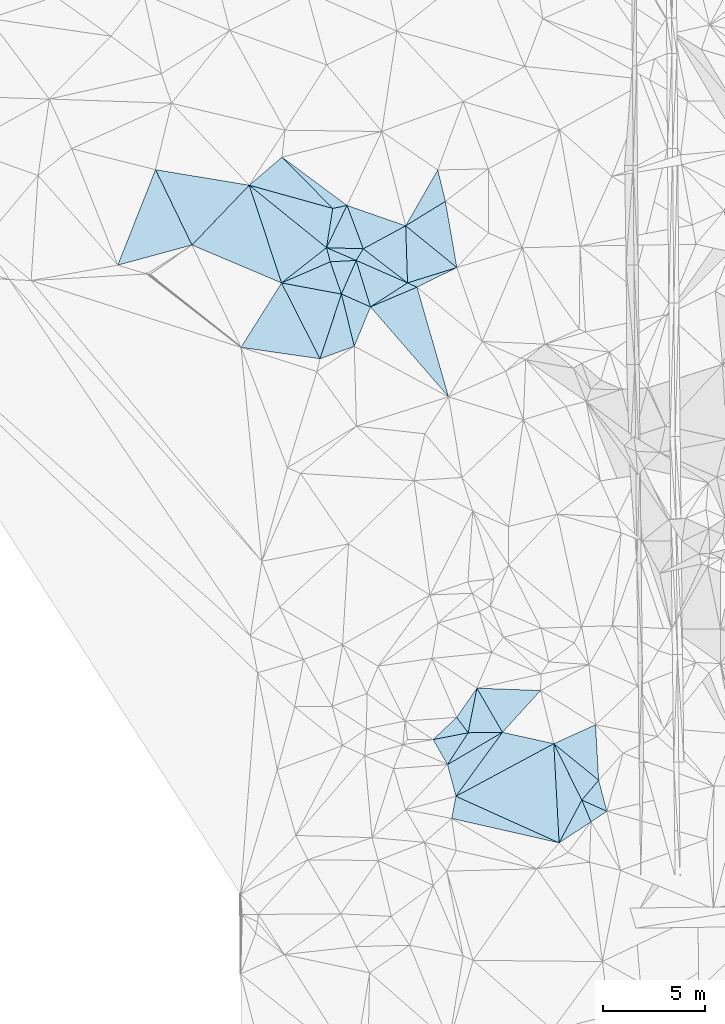
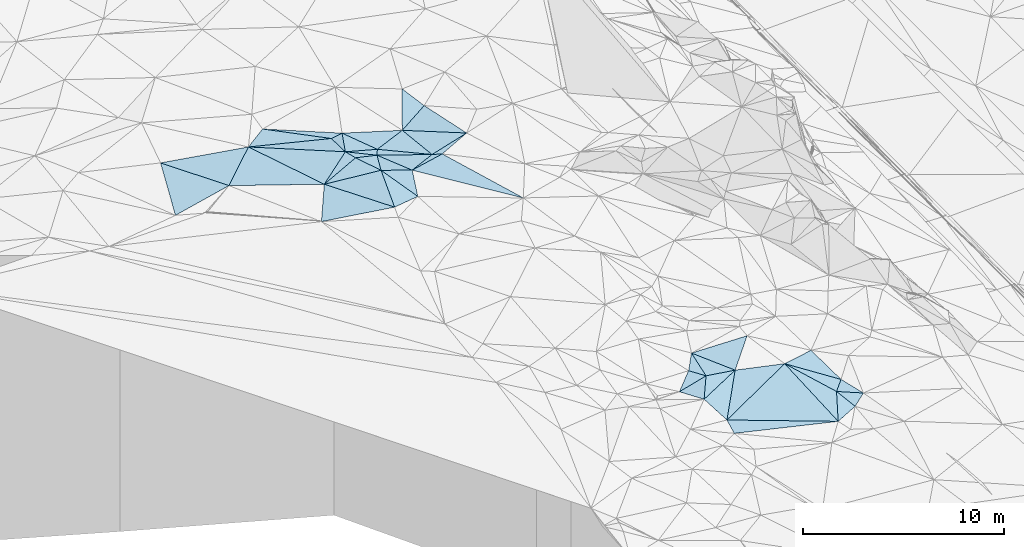
# One storey, part 11 of 275: 45 plates.
"""IFC2X3 building model written with IfcOpenShell, lengths in millimetres."""

from ifc_helpers import new_model, si_unit, frame, origin_with_axes, place, context, subcontext, project, spatial, polyline, outline, extrude, material, type_object, element, save


model = new_model("IFC2X3")

# Units and contexts
model_context = context("Model", 3, precision=1e-05, world=origin_with_axes())
body_context = subcontext(model_context, "Body", "Model", "MODEL_VIEW")
ifc_project = project(units=[si_unit("LENGTHUNIT", "METRE", prefix="MILLI"), si_unit("AREAUNIT", "SQUARE_METRE"), si_unit("VOLUMEUNIT", "CUBIC_METRE"), si_unit("MASSUNIT", "GRAM", prefix="KILO"), si_unit("TIMEUNIT", "SECOND"), si_unit("PLANEANGLEUNIT", "RADIAN"), si_unit("SOLIDANGLEUNIT", "STERADIAN"), si_unit("THERMODYNAMICTEMPERATUREUNIT", "DEGREE_CELSIUS"), si_unit("LUMINOUSINTENSITYUNIT", "LUMEN")], contexts=[model_context])

# Site, building, storey
site_placement = place(None, origin_with_axes())
site = spatial("IfcSite", under=ifc_project, at=site_placement, CompositionType="ELEMENT")
building_placement = place(site_placement, origin_with_axes())
building = spatial("IfcBuilding", under=site, at=building_placement, Name="Undefined", CompositionType="ELEMENT")
storey_placement = place(building_placement, origin_with_axes())
storey = spatial("IfcBuildingStorey", under=building, at=storey_placement, Name="Undefined", CompositionType="ELEMENT", Elevation=0.0)

# Plates
ifc_material = material()
plate_type_1 = type_object("IfcPlateType", PredefinedType="NOTDEFINED")
plate_1_placement = place(storey_placement, frame((-122874.723523103, 30326.0115483348, 46539.50072239), z_axis=(0.0531436009336641, 0.0120552279309635, -0.998514110646082), x_axis=(0.916361367225861, 0.396753114841136, 0.0535612781756311)))
element("IfcPlate", 1, at=plate_1_placement, inside=storey, type_object=plate_type_1, material=ifc_material, Name="00", context=body_context, shape_type="SweptSolid", body=[
    extrude(outline(polyline([(0.0, 0.0), (2613.82861328125, 1.50030246004462e-08), (2487.34741210938, 1671.10815429688), (0.0, 0.0)])), frame((-8.85201319254618e-08, 2.18876761149539e-07, -0.5000001331573), z_axis=(0.0, 0.0, 1.0), x_axis=(1.0, 0.0, 0.0)), (0.0, 0.0, 1.0), 1.0),
])
plate_type_2 = type_object("IfcPlateType", PredefinedType="NOTDEFINED")
plate_2_placement = place(storey_placement, frame((-114310.046556551, 5116.43472786252, 44519.5040770356), z_axis=(-0.0315596022603941, 0.123953906407273, -0.991785975194015), x_axis=(0.586096158666421, 0.806071964587004, 0.0820931221437771)))
element("IfcPlate", 2, at=plate_2_placement, inside=storey, type_object=plate_type_2, material=ifc_material, Name="00", context=body_context, shape_type="SweptSolid", body=[
    extrude(outline(polyline([(0.0, 0.0), (3898.01220703125, -1.19616743177176e-08), (4913.22216796875, 2378.89672851563), (0.0, 0.0)])), frame((-8.85201319254618e-08, 2.18876761149539e-07, -0.5000001331573), z_axis=(0.0, 0.0, 1.0), x_axis=(1.0, 0.0, 0.0)), (0.0, 0.0, 1.0), 1.0),
])
plate_type_3 = type_object("IfcPlateType", PredefinedType="NOTDEFINED")
plate_3_placement = place(storey_placement, frame((-109504.442766531, 7700.1990587645, 44689.5064369855), z_axis=(-0.101255615587192, 0.124276388949899, -0.987067717768965), x_axis=(0.439840597732541, -0.884341412069055, -0.156462505048303)))
element("IfcPlate", 3, at=plate_3_placement, inside=storey, type_object=plate_type_3, material=ifc_material, Name="00", context=body_context, shape_type="SweptSolid", body=[
    extrude(outline(polyline([(0.0, 0.0), (3131.74072265625, 9.22591425478458e-09), (4522.02197265625, 1935.82495117188), (0.0, 0.0)])), frame((-8.85201319254618e-08, 2.18876761149539e-07, -0.5000001331573), z_axis=(0.0, 0.0, 1.0), x_axis=(1.0, 0.0, 0.0)), (0.0, 0.0, 1.0), 1.0),
])
plate_type_4 = type_object("IfcPlateType", PredefinedType="NOTDEFINED")
plate_4_placement = place(storey_placement, frame((-119932.452589548, 29779.0026153179, 46689.5174485164), z_axis=(-0.245713850086967, -0.0909767870247582, -0.965063691213223), x_axis=(-0.32651875351, 0.945171888433115, -0.00596698601103633)))
element("IfcPlate", 4, at=plate_4_placement, inside=storey, type_object=plate_type_4, material=ifc_material, Name="00", context=body_context, shape_type="SweptSolid", body=[
    extrude(outline(polyline([(0.0, 0.0), (1675.88781738281, 3.49245965480804e-10), (1328.84790039063, 1267.69995117188), (0.0, 0.0)])), frame((-8.85201319254618e-08, 2.18876761149539e-07, -0.5000001331573), z_axis=(0.0, 0.0, 1.0), x_axis=(1.0, 0.0, 0.0)), (0.0, 0.0, 1.0), 1.0),
])
plate_type_5 = type_object("IfcPlateType", PredefinedType="NOTDEFINED")
plate_5_placement = place(storey_placement, frame((-114673.667389587, 24734.6013507369, 46229.5063858774), z_axis=(-0.150646443330315, -0.0525157510747159, -0.987191848123243), x_axis=(-0.65426566656042, 0.75390186762396, 0.0597361829493147)))
element("IfcPlate", 5, at=plate_5_placement, inside=storey, type_object=plate_type_5, material=ifc_material, Name="00", context=body_context, shape_type="SweptSolid", body=[
    extrude(outline(polyline([(0.0, 0.0), (5859.095703125, -5.93718141317368e-09), (5069.0078125, 2384.90283203125), (0.0, 0.0)])), frame((-8.85201319254618e-08, 2.18876761149539e-07, -0.5000001331573), z_axis=(0.0, 0.0, 1.0), x_axis=(1.0, 0.0, 0.0)), (0.0, 0.0, 1.0), 1.0),
])
plate_type_6 = type_object("IfcPlateType", PredefinedType="NOTDEFINED")
plate_6_placement = place(storey_placement, frame((-120666.073151548, 32056.7900713835, 46689.5153925274), z_axis=(-0.114899242122029, -0.21794068066864, -0.969174919129397), x_axis=(-0.776703504768069, 0.627947609751592, -0.0491270301184673)))
element("IfcPlate", 6, at=plate_6_placement, inside=storey, type_object=plate_type_6, material=ifc_material, Name="00", context=body_context, shape_type="SweptSolid", body=[
    extrude(outline(polyline([(0.0, 0.0), (4885.29443359375, -1.93394953384995e-08), (996.17333984375, 1744.05810546875), (0.0, 0.0)])), frame((-8.85201319254618e-08, 2.18876761149539e-07, -0.5000001331573), z_axis=(0.0, 0.0, 1.0), x_axis=(1.0, 0.0, 0.0)), (0.0, 0.0, 1.0), 1.0),
])
plate_type_7 = type_object("IfcPlateType", PredefinedType="NOTDEFINED")
plate_7_placement = place(storey_placement, frame((-109504.511511328, 7700.16332637235, 44689.5151481775), z_axis=(-0.238745630059957, 0.0528111330900994, -0.969645042450594), x_axis=(0.756696765543824, -0.615692569641503, -0.219846911972302)))
element("IfcPlate", 7, at=plate_7_placement, inside=storey, type_object=plate_type_7, material=ifc_material, Name="00", context=body_context, shape_type="SweptSolid", body=[
    extrude(outline(polyline([(0.0, 0.0), (2911.11669921875, -2.20461515709758e-09), (2855.2275390625, 1286.65319824219), (0.0, 0.0)])), frame((-8.85201319254618e-08, 2.18876761149539e-07, -0.5000001331573), z_axis=(0.0, 0.0, 1.0), x_axis=(1.0, 0.0, 0.0)), (0.0, 0.0, 1.0), 1.0),
])
plate_8_placement = place(storey_placement, frame((-118507.065997813, 29151.7400005737, 46579.509817536), z_axis=(-0.13783386319787, -0.14129142666446, -0.980325741224351), x_axis=(-0.913018462691783, 0.401786472566067, 0.0704621689053861)))
element("IfcPlate", 8, at=plate_8_placement, inside=storey, type_object=plate_type_7, material=ifc_material, Name="00", context=body_context, shape_type="SweptSolid", body=[
    extrude(outline(polyline([(0.0, 0.0), (1561.12133789063, -9.30231180973351e-09), (1541.32788085938, 1836.43896484375), (0.0, 0.0)])), frame((-8.85201319254618e-08, 2.18876761149539e-07, -0.5000001331573), z_axis=(0.0, 0.0, 1.0), x_axis=(1.0, 0.0, 0.0)), (0.0, 0.0, 1.0), 1.0),
])
plate_type_8 = type_object("IfcPlateType", PredefinedType="NOTDEFINED")
plate_9_placement = place(storey_placement, frame((-116687.273631652, 30328.0134266553, 46179.5069913558), z_axis=(-0.118099315725178, -0.117899530172979, -0.985977815374279), x_axis=(-0.914255549377596, 0.400423346420106, 0.0616273808789021)))
element("IfcPlate", 9, at=plate_9_placement, inside=storey, type_object=plate_type_8, material=ifc_material, Name="00", context=body_context, shape_type="SweptSolid", body=[
    extrude(outline(polyline([(0.0, 0.0), (2758.51416015625, 1.68474798556417e-08), (2660.52661132813, 670.371887207031), (0.0, 0.0)])), frame((-8.85201319254618e-08, 2.18876761149539e-07, -0.5000001331573), z_axis=(0.0, 0.0, 1.0), x_axis=(1.0, 0.0, 0.0)), (0.0, 0.0, 1.0), 1.0),
])
plate_type_9 = type_object("IfcPlateType", PredefinedType="NOTDEFINED")
plate_10_placement = place(storey_placement, frame((-119301.854278411, 27215.0949246617, 46439.5103628386), z_axis=(-0.197198693408515, 0.0469820593359621, -0.97923713237322), x_axis=(-0.925883813147605, -0.337262841748064, 0.170273133897489)))
element("IfcPlate", 10, at=plate_10_placement, inside=storey, type_object=plate_type_9, material=ifc_material, Name="00", context=body_context, shape_type="SweptSolid", body=[
    extrude(outline(polyline([(0.0, 0.0), (1820.60424804688, -2.47382558882236e-09), (-238.32746887207, 2641.4580078125), (0.0, 0.0)])), frame((-8.85201319254618e-08, 2.18876761149539e-07, -0.5000001331573), z_axis=(0.0, 0.0, 1.0), x_axis=(1.0, 0.0, 0.0)), (0.0, 0.0, 1.0), 1.0),
])
plate_type_10 = type_object("IfcPlateType", PredefinedType="NOTDEFINED")
plate_11_placement = place(storey_placement, frame((-116687.258765204, 30327.9746579648, 46179.5116167508), z_axis=(-0.0883655852022608, -0.195436718513792, -0.976727194465488), x_axis=(0.911188905205745, -0.411988809350395, 1.28523827093762e-10)))
element("IfcPlate", 11, at=plate_11_placement, inside=storey, type_object=plate_type_10, material=ifc_material, Name="00", context=body_context, shape_type="SweptSolid", body=[
    extrude(outline(polyline([(0.0, 0.0), (509.901947021484, -3.38695826940238e-09), (-1173.55895996094, 1864.92883300781), (0.0, 0.0)])), frame((-8.85201319254618e-08, 2.18876761149539e-07, -0.5000001331573), z_axis=(0.0, 0.0, 1.0), x_axis=(1.0, 0.0, 0.0)), (0.0, 0.0, 1.0), 1.0),
])
plate_type_11 = type_object("IfcPlateType", PredefinedType="NOTDEFINED")
plate_12_placement = place(storey_placement, frame((-120665.997428059, 32056.7779953323, 46689.5151977644), z_axis=(0.0365449700122325, -0.242093195927164, -0.969564515466906), x_axis=(0.152531261339691, 0.96019582786561, -0.234004671884129)))
element("IfcPlate", 12, at=plate_12_placement, inside=storey, type_object=plate_type_11, material=ifc_material, Name="00", context=body_context, shape_type="SweptSolid", body=[
    extrude(outline(polyline([(0.0, 0.0), (2008.50695800781, -5.12227416038513e-09), (2257.79663085938, 671.1591796875), (0.0, 0.0)])), frame((-8.85201319254618e-08, 2.18876761149539e-07, -0.5000001331573), z_axis=(0.0, 0.0, 1.0), x_axis=(1.0, 0.0, 0.0)), (0.0, 0.0, 1.0), 1.0),
])
plate_type_12 = type_object("IfcPlateType", PredefinedType="NOTDEFINED")
plate_13_placement = place(storey_placement, frame((-119658.782194964, 34131.2894115717, 46209.500347221), z_axis=(-0.00634434563785421, -0.038025259409611, -0.999256638169224), x_axis=(-0.978931332884387, -0.203711466602917, 0.0139672428090175)))
element("IfcPlate", 13, at=plate_13_placement, inside=storey, type_object=plate_type_12, material=ifc_material, Name="00", context=body_context, shape_type="SweptSolid", body=[
    extrude(outline(polyline([(0.0, 0.0), (715.960876464844, -4.36557456851006e-11), (2640.22802734375, 2974.4404296875), (0.0, 0.0)])), frame((-8.85201319254618e-08, 2.18876761149539e-07, -0.5000001331573), z_axis=(0.0, 0.0, 1.0), x_axis=(1.0, 0.0, 0.0)), (0.0, 0.0, 1.0), 1.0),
])
plate_type_13 = type_object("IfcPlateType", PredefinedType="NOTDEFINED")
plate_14_placement = place(storey_placement, frame((-119209.32558362, 31432.6194159957, 46349.5163674946), z_axis=(-0.248366390447094, -0.0528103549128788, -0.967225517917232), x_axis=(-0.966518045018754, -0.0529508716622426, 0.251075832854009)))
element("IfcPlate", 14, at=plate_14_placement, inside=storey, type_object=plate_type_13, material=ifc_material, Name="00", context=body_context, shape_type="SweptSolid", body=[
    extrude(outline(polyline([(0.0, 0.0), (1314.34399414063, -8.26548784971237e-09), (1460.34838867188, 703.550109863281), (0.0, 0.0)])), frame((-8.85201319254618e-08, 2.18876761149539e-07, -0.5000001331573), z_axis=(0.0, 0.0, 1.0), x_axis=(1.0, 0.0, 0.0)), (0.0, 0.0, 1.0), 1.0),
])
plate_type_14 = type_object("IfcPlateType", PredefinedType="NOTDEFINED")
plate_15_placement = place(storey_placement, frame((-115202.061008349, 35872.0669443112, 46279.5043114669), z_axis=(-0.0326268093323333, 0.127243543863493, -0.991334742585899), x_axis=(0.234357335501292, -0.963236104578067, -0.131350089965732)))
element("IfcPlate", 15, at=plate_15_placement, inside=storey, type_object=plate_type_14, material=ifc_material, Name="00", context=body_context, shape_type="SweptSolid", body=[
    extrude(outline(polyline([(0.0, 0.0), (1598.78076171875, 2.09547579288483e-09), (2310.6357421875, 2179.53271484375), (0.0, 0.0)])), frame((-8.85201319254618e-08, 2.18876761149539e-07, -0.5000001331573), z_axis=(0.0, 0.0, 1.0), x_axis=(1.0, 0.0, 0.0)), (0.0, 0.0, 1.0), 1.0),
])
plate_type_15 = type_object("IfcPlateType", PredefinedType="NOTDEFINED")
plate_16_placement = place(storey_placement, frame((-108126.915510413, 4930.79155043213, 44199.5346321454), z_axis=(0.0198296046099617, 0.365299405956121, -0.930678854809282), x_axis=(0.903421382909208, -0.405308608278266, -0.139838252842167)))
element("IfcPlate", 16, at=plate_16_placement, inside=storey, type_object=plate_type_15, material=ifc_material, Name="00", context=body_context, shape_type="SweptSolid", body=[
    extrude(outline(polyline([(0.0, 0.0), (1358.71264648438, -8.37462721392512e-09), (897.835205078125, 841.422607421875), (0.0, 0.0)])), frame((-8.85201319254618e-08, 2.18876761149539e-07, -0.5000001331573), z_axis=(0.0, 0.0, 1.0), x_axis=(1.0, 0.0, 0.0)), (0.0, 0.0, 1.0), 1.0),
])
plate_type_16 = type_object("IfcPlateType", PredefinedType="NOTDEFINED")
plate_17_placement = place(storey_placement, frame((-114265.144897883, 31081.7821624912, 46179.4999807117), z_axis=(-2.50206221658913e-11, -2.85783213693808e-11, -1.0), x_axis=(-0.897149848914163, -0.441726327711282, -1.45655409870409e-10)))
element("IfcPlate", 17, at=plate_17_placement, inside=storey, type_object=plate_type_16, material=ifc_material, Name="00", context=body_context, shape_type="SweptSolid", body=[
    extrude(outline(polyline([(0.0, 0.0), (2181.85693359375, 2.6775524020195e-09), (2505.89282226563, 393.701324462891), (0.0, 0.0)])), frame((-8.85201319254618e-08, 2.18876761149539e-07, -0.5000001331573), z_axis=(0.0, 0.0, 1.0), x_axis=(1.0, 0.0, 0.0)), (0.0, 0.0, 1.0), 1.0),
])
plate_type_17 = type_object("IfcPlateType", PredefinedType="NOTDEFINED")
plate_18_placement = place(storey_placement, frame((-113709.987516198, 8235.34827615239, 45099.5035817808), z_axis=(-0.117730516555391, -0.0221639176814173, -0.99279821022432), x_axis=(-0.596901066282499, 0.800568276263145, 0.0529107939070345)))
element("IfcPlate", 18, at=plate_18_placement, inside=storey, type_object=plate_type_17, material=ifc_material, Name="00", context=body_context, shape_type="SweptSolid", body=[
    extrude(outline(polyline([(0.0, 0.0), (944.986755371094, -2.77941580861807e-09), (1491.87268066406, 1664.81701660156), (0.0, 0.0)])), frame((-8.85201319254618e-08, 2.18876761149539e-07, -0.5000001331573), z_axis=(0.0, 0.0, 1.0), x_axis=(1.0, 0.0, 0.0)), (0.0, 0.0, 1.0), 1.0),
])
plate_type_18 = type_object("IfcPlateType", PredefinedType="NOTDEFINED")
plate_19_placement = place(storey_placement, frame((-107301.681285739, 5907.80747038245, 44049.5155684937), z_axis=(-0.243352276937575, 0.0468498299284834, -0.96880584367817), x_axis=(-0.756696765550476, 0.615692569636882, 0.219846911962351)))
element("IfcPlate", 19, at=plate_19_placement, inside=storey, type_object=plate_type_18, material=ifc_material, Name="00", context=body_context, shape_type="SweptSolid", body=[
    extrude(outline(polyline([(0.0, 0.0), (2911.11669921875, -2.20461515709758e-09), (1828.13012695313, 2027.54541015625), (0.0, 0.0)])), frame((-8.85201319254618e-08, 2.18876761149539e-07, -0.5000001331573), z_axis=(0.0, 0.0, 1.0), x_axis=(1.0, 0.0, 0.0)), (0.0, 0.0, 1.0), 1.0),
])
plate_type_19 = type_object("IfcPlateType", PredefinedType="NOTDEFINED")
plate_20_placement = place(storey_placement, frame((-112025.513897882, 8258.56753793954, 44839.5227024943), z_axis=(-0.186321650672729, 0.232688046092679, -0.954536806883926), x_axis=(-0.586096158663583, -0.806071964585224, -0.0820931221815179)))
element("IfcPlate", 20, at=plate_20_placement, inside=storey, type_object=plate_type_19, material=ifc_material, Name="00", context=body_context, shape_type="SweptSolid", body=[
    extrude(outline(polyline([(0.0, 0.0), (3898.01220703125, -1.19616743177176e-08), (2849.349609375, 1304.80139160156), (0.0, 0.0)])), frame((-8.85201319254618e-08, 2.18876761149539e-07, -0.5000001331573), z_axis=(0.0, 0.0, 1.0), x_axis=(1.0, 0.0, 0.0)), (0.0, 0.0, 1.0), 1.0),
])
plate_type_20 = type_object("IfcPlateType", PredefinedType="NOTDEFINED")
plate_21_placement = place(storey_placement, frame((-119209.322728371, 31432.6266539714, 46349.5153032014), z_axis=(-0.242659621652531, -0.038333327579924, -0.969353838397569), x_axis=(-0.898720339216456, 0.38510678034798, 0.209748705856964)))
element("IfcPlate", 21, at=plate_21_placement, inside=storey, type_object=plate_type_20, material=ifc_material, Name="00", context=body_context, shape_type="SweptSolid", body=[
    extrude(outline(polyline([(0.0, 0.0), (1620.9873046875, -3.20142135024071e-10), (-117.582656860352, 667.2138671875), (0.0, 0.0)])), frame((-8.85201319254618e-08, 2.18876761149539e-07, -0.5000001331573), z_axis=(0.0, 0.0, 1.0), x_axis=(1.0, 0.0, 0.0)), (0.0, 0.0, 1.0), 1.0),
])
plate_type_21 = type_object("IfcPlateType", PredefinedType="NOTDEFINED")
plate_22_placement = place(storey_placement, frame((-122874.727774278, 30325.9886854063, 46539.5007618759), z_axis=(0.044639755858827, -0.0336706450984905, -0.998435566201203), x_axis=(0.981925729063972, -0.182527135337057, 0.0500570421402868)))
element("IfcPlate", 22, at=plate_22_placement, inside=storey, type_object=plate_type_21, material=ifc_material, Name="00", context=body_context, shape_type="SweptSolid", body=[
    extrude(outline(polyline([(0.0, 0.0), (2996.58129882813, -7.80073605710641e-09), (2543.6318359375, 3318.33349609375), (0.0, 0.0)])), frame((-8.85201319254618e-08, 2.18876761149539e-07, -0.5000001331573), z_axis=(0.0, 0.0, 1.0), x_axis=(1.0, 0.0, 0.0)), (0.0, 0.0, 1.0), 1.0),
])
plate_type_22 = type_object("IfcPlateType", PredefinedType="NOTDEFINED")
plate_23_placement = place(storey_placement, frame((-120665.992351375, 32056.9125129815, 46689.5007071103), z_axis=(0.0466998317498566, 0.0269423333832299, -0.998545560496066), x_axis=(0.259522249664595, -0.965636844828202, -0.0139171059945497)))
element("IfcPlate", 23, at=plate_23_placement, inside=storey, type_object=plate_type_22, material=ifc_material, Name="00", context=body_context, shape_type="SweptSolid", body=[
    extrude(outline(polyline([(0.0, 0.0), (718.540161132813, -8.87666828930378e-10), (1100.28637695313, 2585.80151367188), (0.0, 0.0)])), frame((-8.85201319254618e-08, 2.18876761149539e-07, -0.5000001331573), z_axis=(0.0, 0.0, 1.0), x_axis=(1.0, 0.0, 0.0)), (0.0, 0.0, 1.0), 1.0),
])
plate_type_23 = type_object("IfcPlateType", PredefinedType="NOTDEFINED")
plate_24_placement = place(storey_placement, frame((-108127.076995136, 4930.72246522424, 44199.5372301573), z_axis=(-0.303140859323505, 0.227129190210744, -0.925482550004493), x_axis=(0.366315262759476, -0.868786555188984, -0.333201215172325)))
element("IfcPlate", 24, at=plate_24_placement, inside=storey, type_object=plate_type_23, material=ifc_material, Name="00", context=body_context, shape_type="SweptSolid", body=[
    extrude(outline(polyline([(0.0, 0.0), (1230.48767089844, 2.44472175836563e-09), (1466.16662597656, 1879.00390625), (0.0, 0.0)])), frame((-8.85201319254618e-08, 2.18876761149539e-07, -0.5000001331573), z_axis=(0.0, 0.0, 1.0), x_axis=(1.0, 0.0, 0.0)), (0.0, 0.0, 1.0), 1.0),
])
plate_type_24 = type_object("IfcPlateType", PredefinedType="NOTDEFINED")
plate_25_placement = place(storey_placement, frame((-114273.957568723, 8991.94434832169, 45149.5046228551), z_axis=(0.0692932974377679, 0.117141408337184, -0.99069487198783), x_axis=(0.596901066241312, -0.80056827629156, -0.0529107939417387)))
element("IfcPlate", 25, at=plate_25_placement, inside=storey, type_object=plate_type_24, material=ifc_material, Name="00", context=body_context, shape_type="SweptSolid", body=[
    extrude(outline(polyline([(0.0, 0.0), (944.986755371094, -2.77941580861807e-09), (193.759323120117, 1592.93981933594), (0.0, 0.0)])), frame((-8.85201319254618e-08, 2.18876761149539e-07, -0.5000001331573), z_axis=(0.0, 0.0, 1.0), x_axis=(1.0, 0.0, 0.0)), (0.0, 0.0, 1.0), 1.0),
])
plate_type_25 = type_object("IfcPlateType", PredefinedType="NOTDEFINED")
plate_26_placement = place(storey_placement, frame((-113279.256382948, 10426.6426730669, 44999.5058641992), z_axis=(-0.152320989072698, -0.0151552068004944, -0.988214873392801), x_axis=(0.49956524630939, -0.863927178298952, -0.0637526099563791)))
element("IfcPlate", 26, at=plate_26_placement, inside=storey, type_object=plate_type_25, material=ifc_material, Name="00", context=body_context, shape_type="SweptSolid", body=[
    extrude(outline(polyline([(0.0, 0.0), (2509.701171875, -3.66708263754845e-09), (1671.55358886719, 1484.32092285156), (0.0, 0.0)])), frame((-8.85201319254618e-08, 2.18876761149539e-07, -0.5000001331573), z_axis=(0.0, 0.0, 1.0), x_axis=(1.0, 0.0, 0.0)), (0.0, 0.0, 1.0), 1.0),
])
plate_type_26 = type_object("IfcPlateType", PredefinedType="NOTDEFINED")
plate_27_placement = place(storey_placement, frame((-116778.159448635, 33130.5765376592, 45979.5013440169), z_axis=(0.0219253263728473, -0.0704577140078722, -0.997273779160081), x_axis=(0.773586584043883, -0.630692798167964, 0.0615661540652075)))
element("IfcPlate", 27, at=plate_27_placement, inside=storey, type_object=plate_type_26, material=ifc_material, Name="00", context=body_context, shape_type="SweptSolid", body=[
    extrude(outline(polyline([(0.0, 0.0), (3248.5380859375, 1.81171344593167e-09), (1850.216796875, 2116.41137695313), (0.0, 0.0)])), frame((-8.85201319254618e-08, 2.18876761149539e-07, -0.5000001331573), z_axis=(0.0, 0.0, 1.0), x_axis=(1.0, 0.0, 0.0)), (0.0, 0.0, 1.0), 1.0),
])
plate_type_27 = type_object("IfcPlateType", PredefinedType="NOTDEFINED")
plate_28_placement = place(storey_placement, frame((-119658.827483661, 34131.2832568399, 46209.5029692526), z_axis=(-0.096862858818181, -0.0503636843519466, -0.994022678755403), x_axis=(0.941948951320927, -0.327224311383804, -0.0752091958792336)))
element("IfcPlate", 28, at=plate_28_placement, inside=storey, type_object=plate_type_27, material=ifc_material, Name="00", context=body_context, shape_type="SweptSolid", body=[
    extrude(outline(polyline([(0.0, 0.0), (3058.13671875, -1.64636730914935e-08), (1446.89416503906, 1754.19421386719), (0.0, 0.0)])), frame((-8.85201319254618e-08, 2.18876761149539e-07, -0.5000001331573), z_axis=(0.0, 0.0, 1.0), x_axis=(1.0, 0.0, 0.0)), (0.0, 0.0, 1.0), 1.0),
])
plate_type_28 = type_object("IfcPlateType", PredefinedType="NOTDEFINED")
plate_29_placement = place(storey_placement, frame((-114724.240853784, 6671.69341008617, 44979.5020382682), z_axis=(0.0889023501413768, 0.0187538671393597, -0.995863778137683), x_axis=(-0.498629111392954, 0.866356658471301, -0.0281983970096632)))
element("IfcPlate", 29, at=plate_29_placement, inside=storey, type_object=plate_type_28, material=ifc_material, Name="00", context=body_context, shape_type="SweptSolid", body=[
    extrude(outline(polyline([(0.0, 0.0), (1418.52038574219, 5.0931703299284e-09), (845.528930664063, 1665.37707519531), (0.0, 0.0)])), frame((-8.85201319254618e-08, 2.18876761149539e-07, -0.5000001331573), z_axis=(0.0, 0.0, 1.0), x_axis=(1.0, 0.0, 0.0)), (0.0, 0.0, 1.0), 1.0),
])
plate_type_29 = type_object("IfcPlateType", PredefinedType="NOTDEFINED")
plate_30_placement = place(storey_placement, frame((-109242.882999465, 2830.05568836738, 44049.5024714481), z_axis=(-0.0545351740956989, 0.0836747873966004, -0.994999720975079), x_axis=(-0.972594213030152, 0.221112301371748, 0.0719016478416826)))
element("IfcPlate", 30, at=plate_30_placement, inside=storey, type_object=plate_type_29, material=ifc_material, Name="00", context=body_context, shape_type="SweptSolid", body=[
    extrude(outline(polyline([(0.0, 0.0), (5424.076171875, -3.19050741381943e-08), (5467.64111328125, 1108.8291015625), (0.0, 0.0)])), frame((-8.85201319254618e-08, 2.18876761149539e-07, -0.5000001331573), z_axis=(0.0, 0.0, 1.0), x_axis=(1.0, 0.0, 0.0)), (0.0, 0.0, 1.0), 1.0),
])
plate_type_30 = type_object("IfcPlateType", PredefinedType="NOTDEFINED")
plate_31_placement = place(storey_placement, frame((-119932.348857579, 29779.0919293727, 46689.5022717985), z_axis=(-0.0382491877477777, 0.0876510373419387, -0.995416644068963), x_axis=(0.913018462690582, -0.401786472568513, -0.0704621689070016)))
element("IfcPlate", 31, at=plate_31_placement, inside=storey, type_object=plate_type_30, material=ifc_material, Name="00", context=body_context, shape_type="SweptSolid", body=[
    extrude(outline(polyline([(0.0, 0.0), (1561.12133789063, -9.30231180973351e-09), (1623.51245117188, 2097.21411132813), (0.0, 0.0)])), frame((-8.85201319254618e-08, 2.18876761149539e-07, -0.5000001331573), z_axis=(0.0, 0.0, 1.0), x_axis=(1.0, 0.0, 0.0)), (0.0, 0.0, 1.0), 1.0),
])
plate_type_31 = type_object("IfcPlateType", PredefinedType="NOTDEFINED")
plate_32_placement = place(storey_placement, frame((-112025.414435927, 8258.49160922664, 44839.5016462068), z_axis=(0.012593079425591, 0.0808285781338789, -0.996648461247714), x_axis=(-0.499565246307892, 0.863927178300214, 0.0637526099510104)))
element("IfcPlate", 32, at=plate_32_placement, inside=storey, type_object=plate_type_31, material=ifc_material, Name="00", context=body_context, shape_type="SweptSolid", body=[
    extrude(outline(polyline([(0.0, 0.0), (2509.701171875, -3.66708263754845e-09), (850.061340332031, 2649.43310546875), (0.0, 0.0)])), frame((-8.85201319254618e-08, 2.18876761149539e-07, -0.5000001331573), z_axis=(0.0, 0.0, 1.0), x_axis=(1.0, 0.0, 0.0)), (0.0, 0.0, 1.0), 1.0),
])
plate_type_32 = type_object("IfcPlateType", PredefinedType="NOTDEFINED")
plate_33_placement = place(storey_placement, frame((-106899.5154248, 4379.90283159324, 44009.5064861301), z_axis=(-0.160080000007614, -0.0162927557663062, -0.986969573850735), x_axis=(-0.903421382907949, 0.405308608280224, 0.139838252844626)))
element("IfcPlate", 33, at=plate_33_placement, inside=storey, type_object=plate_type_32, material=ifc_material, Name="00", context=body_context, shape_type="SweptSolid", body=[
    extrude(outline(polyline([(0.0, 0.0), (1358.71264648438, -8.37462721392512e-09), (988.141235351563, 1233.40051269531), (0.0, 0.0)])), frame((-8.85201319254618e-08, 2.18876761149539e-07, -0.5000001331573), z_axis=(0.0, 0.0, 1.0), x_axis=(1.0, 0.0, 0.0)), (0.0, 0.0, 1.0), 1.0),
])
plate_type_33 = type_object("IfcPlateType", PredefinedType="NOTDEFINED")
plate_34_placement = place(storey_placement, frame((-114724.361582364, 6671.77084455885, 44979.513507855), z_axis=(-0.152548936215426, 0.173623055622382, -0.972925411640527), x_axis=(0.543097199388409, 0.837208137188425, 0.0642492571315361)))
element("IfcPlate", 34, at=plate_34_placement, inside=storey, type_object=plate_type_33, material=ifc_material, Name="00", context=body_context, shape_type="SweptSolid", body=[
    extrude(outline(polyline([(0.0, 0.0), (1867.72583007813, 2.03726813197136e-10), (2785.20532226563, 1436.63903808594), (0.0, 0.0)])), frame((-8.85201319254618e-08, 2.18876761149539e-07, -0.5000001331573), z_axis=(0.0, 0.0, 1.0), x_axis=(1.0, 0.0, 0.0)), (0.0, 0.0, 1.0), 1.0),
])
plate_type_34 = type_object("IfcPlateType", PredefinedType="NOTDEFINED")
plate_35_placement = place(storey_placement, frame((-109242.8727236, 2830.07806296768, 44049.5044025883), z_axis=(-0.0339857464310266, 0.128423674662794, -0.99113688702703), x_axis=(-0.908268010150821, 0.409819401385373, 0.0842453558648935)))
element("IfcPlate", 35, at=plate_35_placement, inside=storey, type_object=plate_type_34, material=ifc_material, Name="00", context=body_context, shape_type="SweptSolid", body=[
    extrude(outline(polyline([(0.0, 0.0), (5578.9423828125, 1.86191755346954e-08), (2287.3330078125, 4354.79150390625), (0.0, 0.0)])), frame((-8.85201319254618e-08, 2.18876761149539e-07, -0.5000001331573), z_axis=(0.0, 0.0, 1.0), x_axis=(1.0, 0.0, 0.0)), (0.0, 0.0, 1.0), 1.0),
])
plate_type_35 = type_object("IfcPlateType", PredefinedType="NOTDEFINED")
plate_36_placement = place(storey_placement, frame((-122874.798001979, 30325.9803402442, 46539.5029151955), z_axis=(-0.0958887579892078, -0.0503314483819701, -0.994118751153533), x_axis=(-0.91877694854995, 0.388710679557772, 0.0689414709081387)))
element("IfcPlate", 36, at=plate_36_placement, inside=storey, type_object=plate_type_35, material=ifc_material, Name="00", context=body_context, shape_type="SweptSolid", body=[
    extrude(outline(polyline([(0.0, 0.0), (4786.6689453125, 6.35191099718213e-09), (3315.95947265625, 3814.90673828125), (0.0, 0.0)])), frame((-8.85201319254618e-08, 2.18876761149539e-07, -0.5000001331573), z_axis=(0.0, 0.0, 1.0), x_axis=(1.0, 0.0, 0.0)), (0.0, 0.0, 1.0), 1.0),
])
plate_type_36 = type_object("IfcPlateType", PredefinedType="NOTDEFINED")
plate_37_placement = place(storey_placement, frame((-124460.408098851, 35124.6093410723, 46449.5010497781), z_axis=(0.0654766843539479, 0.00292153665524992, -0.997849822583331), x_axis=(0.776703504722462, -0.627947609810518, 0.0491270300863193)))
element("IfcPlate", 37, at=plate_37_placement, inside=storey, type_object=plate_type_36, material=ifc_material, Name="00", context=body_context, shape_type="SweptSolid", body=[
    extrude(outline(polyline([(0.0, 0.0), (4885.29443359375, -1.93394953384995e-08), (4249.3037109375, 2737.24609375), (0.0, 0.0)])), frame((-8.85201319254618e-08, 2.18876761149539e-07, -0.5000001331573), z_axis=(0.0, 0.0, 1.0), x_axis=(1.0, 0.0, 0.0)), (0.0, 0.0, 1.0), 1.0),
])
plate_type_37 = type_object("IfcPlateType", PredefinedType="NOTDEFINED")
plate_38_placement = place(storey_placement, frame((-127272.631914537, 32186.6021669284, 46869.5010446296), z_axis=(-0.00146041090850723, -0.0653895572030585, -0.997858744015788), x_axis=(-0.965026133413053, -0.261496703475699, 0.0185482047970846)))
element("IfcPlate", 38, at=plate_38_placement, inside=storey, type_object=plate_type_37, material=ifc_material, Name="00", context=body_context, shape_type="SweptSolid", body=[
    extrude(outline(polyline([(0.0, 0.0), (3773.9501953125, -1.31403794512153e-08), (754.673461914063, 4049.66259765625), (0.0, 0.0)])), frame((-8.85201319254618e-08, 2.18876761149539e-07, -0.5000001331573), z_axis=(0.0, 0.0, 1.0), x_axis=(1.0, 0.0, 0.0)), (0.0, 0.0, 1.0), 1.0),
])
plate_type_38 = type_object("IfcPlateType", PredefinedType="NOTDEFINED")
plate_39_placement = place(storey_placement, frame((-129062.555334363, 35889.0169166643, 46629.5027581191), z_axis=(-0.0539337031700547, -0.0905350408358309, -0.99443177847614), x_axis=(0.985749294046853, -0.163743146378524, -0.038555301842827)))
element("IfcPlate", 39, at=plate_39_placement, inside=storey, type_object=plate_type_38, material=ifc_material, Name="00", context=body_context, shape_type="SweptSolid", body=[
    extrude(outline(polyline([(0.0, 0.0), (4668.61865234375, -2.18860805034637e-08), (2361.3837890625, 3375.37646484375), (0.0, 0.0)])), frame((-8.85201319254618e-08, 2.18876761149539e-07, -0.5000001331573), z_axis=(0.0, 0.0, 1.0), x_axis=(1.0, 0.0, 0.0)), (0.0, 0.0, 1.0), 1.0),
])
plate_type_39 = type_object("IfcPlateType", PredefinedType="NOTDEFINED")
plate_40_placement = place(storey_placement, frame((-116687.256685641, 30328.0355519733, 46179.5031188154), z_axis=(-0.0842073953421483, -0.0736488167670012, -0.993722781442849), x_axis=(-0.791856394239524, 0.610315675327825, 0.0218684098900654)))
element("IfcPlate", 40, at=plate_40_placement, inside=storey, type_object=plate_type_39, material=ifc_material, Name="00", context=body_context, shape_type="SweptSolid", body=[
    extrude(outline(polyline([(0.0, 0.0), (2743.68359375, -1.087028067559e-08), (1778.083984375, 2177.36474609375), (0.0, 0.0)])), frame((-8.85201319254618e-08, 2.18876761149539e-07, -0.5000001331573), z_axis=(0.0, 0.0, 1.0), x_axis=(1.0, 0.0, 0.0)), (0.0, 0.0, 1.0), 1.0),
])
plate_type_40 = type_object("IfcPlateType", PredefinedType="NOTDEFINED")
plate_41_placement = place(storey_placement, frame((-119658.900765984, 34131.2559691703, 46209.5178602356), z_axis=(-0.243387340554608, -0.104938069754944, -0.964235761613238), x_axis=(0.351358874663139, -0.936147896177753, 0.0131930920340897)))
element("IfcPlate", 41, at=plate_41_placement, inside=storey, type_object=plate_type_40, material=ifc_material, Name="00", context=body_context, shape_type="SweptSolid", body=[
    extrude(outline(polyline([(0.0, 0.0), (2273.91723632813, -1.62981450557709e-09), (1594.38513183594, 1733.79235839844), (0.0, 0.0)])), frame((-8.85201319254618e-08, 2.18876761149539e-07, -0.5000001331573), z_axis=(0.0, 0.0, 1.0), x_axis=(1.0, 0.0, 0.0)), (0.0, 0.0, 1.0), 1.0),
])
plate_type_41 = type_object("IfcPlateType", PredefinedType="NOTDEFINED")
plate_42_placement = place(storey_placement, frame((-120359.699864731, 33985.3995014163, 46219.5055102015), z_axis=(-0.0885203880161352, -0.118989284523838, -0.988941702565919), x_axis=(-0.962111532011941, 0.267263029288868, 0.0539617748501026)))
element("IfcPlate", 42, at=plate_42_placement, inside=storey, type_object=plate_type_41, material=ifc_material, Name="00", context=body_context, shape_type="SweptSolid", body=[
    extrude(outline(polyline([(0.0, 0.0), (4262.2763671875, -2.06582626560703e-08), (3065.02880859375, 1776.42846679688), (0.0, 0.0)])), frame((-8.85201319254618e-08, 2.18876761149539e-07, -0.5000001331573), z_axis=(0.0, 0.0, 1.0), x_axis=(1.0, 0.0, 0.0)), (0.0, 0.0, 1.0), 1.0),
])
plate_type_42 = type_object("IfcPlateType", PredefinedType="NOTDEFINED")
plate_43_placement = place(storey_placement, frame((-114265.114690872, 31081.7704993697, 46179.5010307232), z_axis=(0.060402103254516, -0.0233246759419016, -0.997901571005195), x_axis=(-0.773586584045562, 0.630692798165951, -0.0615661540647284)))
element("IfcPlate", 43, at=plate_43_placement, inside=storey, type_object=plate_type_42, material=ifc_material, Name="00", context=body_context, shape_type="SweptSolid", body=[
    extrude(outline(polyline([(0.0, 0.0), (3248.5380859375, 1.81171344593167e-09), (2491.58227539063, 2164.2822265625), (0.0, 0.0)])), frame((-8.85201319254618e-08, 2.18876761149539e-07, -0.5000001331573), z_axis=(0.0, 0.0, 1.0), x_axis=(1.0, 0.0, 0.0)), (0.0, 0.0, 1.0), 1.0),
])
plate_type_43 = type_object("IfcPlateType", PredefinedType="NOTDEFINED")
plate_44_placement = place(storey_placement, frame((-119209.26473797, 31432.57679377, 46349.508834963), z_axis=(-0.126678378744405, -0.138055033664008, -0.982289873733166), x_axis=(0.914255549378498, -0.400423346417775, -0.0616273808806738)))
element("IfcPlate", 44, at=plate_44_placement, inside=storey, type_object=plate_type_43, material=ifc_material, Name="00", context=body_context, shape_type="SweptSolid", body=[
    extrude(outline(polyline([(0.0, 0.0), (2758.51416015625, 1.68474798556417e-08), (1541.11950683594, 1836.61389160156), (0.0, 0.0)])), frame((-8.85201319254618e-08, 2.18876761149539e-07, -0.5000001331573), z_axis=(0.0, 0.0, 1.0), x_axis=(1.0, 0.0, 0.0)), (0.0, 0.0, 1.0), 1.0),
])
plate_type_44 = type_object("IfcPlateType", PredefinedType="NOTDEFINED")
plate_45_placement = place(storey_placement, frame((-120987.447488987, 26601.0091489427, 46749.5021584922), z_axis=(-0.0475320385405802, -0.0802140025247853, -0.995643720972081), x_axis=(-0.989101565350435, 0.142838192373744, 0.0357119618716291)))
element("IfcPlate", 45, at=plate_45_placement, inside=storey, type_object=plate_type_44, material=ifc_material, Name="00", context=body_context, shape_type="SweptSolid", body=[
    extrude(outline(polyline([(0.0, 0.0), (3920.25512695313, 1.28347892314196e-08), (2391.32397460938, 3429.71850585938), (0.0, 0.0)])), frame((-8.85201319254618e-08, 2.18876761149539e-07, -0.5000001331573), z_axis=(0.0, 0.0, 1.0), x_axis=(1.0, 0.0, 0.0)), (0.0, 0.0, 1.0), 1.0),
])

save(model, "model.ifc")
